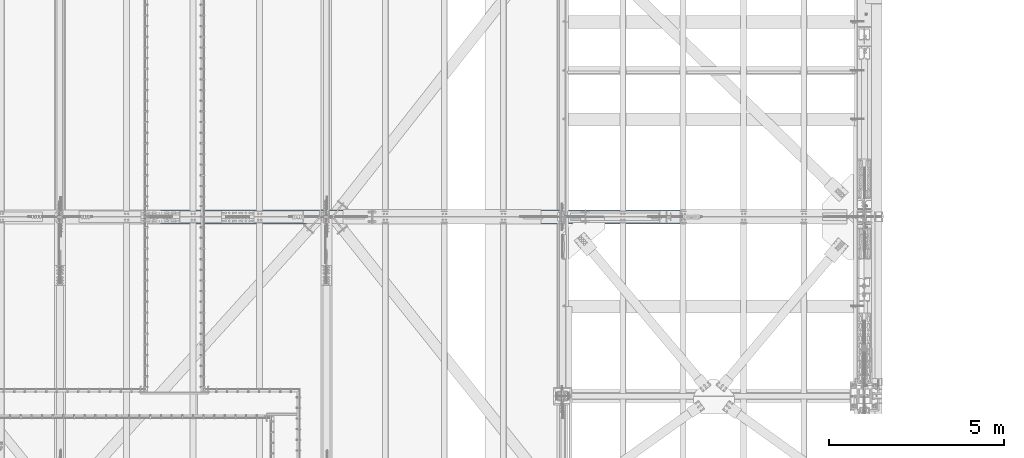
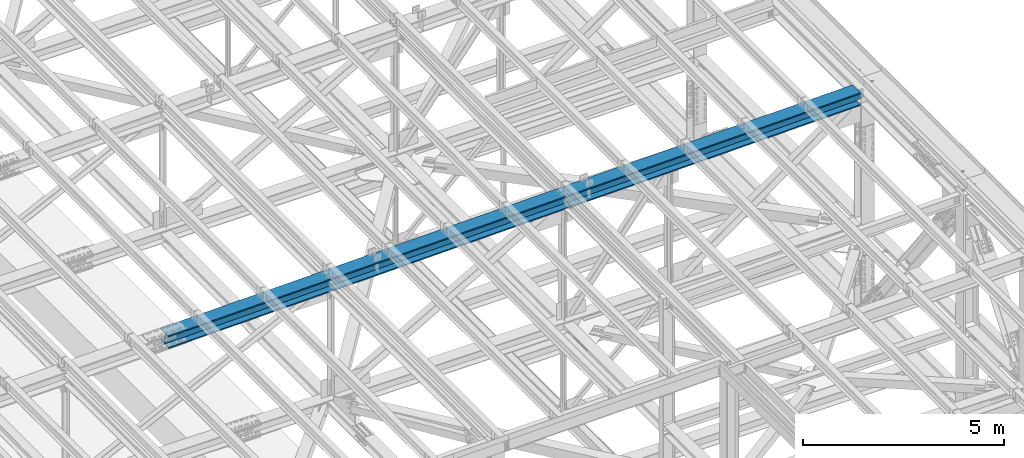
# One storey, part 1834 of 3843: 1 beam, 1 element without a shape of its own.
"""IFC2X3 building model written with IfcOpenShell, lengths in millimetres."""

from ifc_helpers import new_model, si_unit, frame, origin_with_axes, place, context, subcontext, project, spatial, faceted_brep, material, type_object, element, aggregate, save


model = new_model("IFC2X3")

# Units and contexts
model_context = context("Model", 3, precision=1e-05, world=origin_with_axes())
body_context = subcontext(model_context, "Body", "Model", "MODEL_VIEW")
ifc_project = project(units=[si_unit("LENGTHUNIT", "METRE", prefix="MILLI"), si_unit("AREAUNIT", "SQUARE_METRE"), si_unit("VOLUMEUNIT", "CUBIC_METRE"), si_unit("MASSUNIT", "GRAM", prefix="KILO"), si_unit("TIMEUNIT", "SECOND"), si_unit("PLANEANGLEUNIT", "RADIAN"), si_unit("SOLIDANGLEUNIT", "STERADIAN"), si_unit("THERMODYNAMICTEMPERATUREUNIT", "DEGREE_CELSIUS"), si_unit("LUMINOUSINTENSITYUNIT", "LUMEN")], contexts=[model_context])

# Site, building, storey
site_placement = place(None, origin_with_axes())
site = spatial("IfcSite", under=ifc_project, at=site_placement, CompositionType="ELEMENT")
building_placement = place(site_placement, origin_with_axes())
building = spatial("IfcBuilding", under=site, at=building_placement, Name="Undefined", CompositionType="ELEMENT")
storey_placement = place(building_placement, origin_with_axes())
storey = spatial("IfcBuildingStorey", under=building, at=storey_placement, Name="Undefined", CompositionType="ELEMENT", Elevation=0.0)

# Assembly, beam
assembly_placement = place(storey_placement, origin_with_axes())
assembly = element("IfcElementAssembly", 1, at=assembly_placement, inside=storey, Name="BEAM", AssemblyPlace="NOTDEFINED", PredefinedType="RIGID_FRAME")
ifc_material = material(Name="STEEL/A992")
beam_type = type_object("IfcBeamType", Name="W14X193", PredefinedType="NOTDEFINED")
beam_placement = place(assembly_placement, frame((65510.8587019639, 33845.5, 45847.6094284159), z_axis=(-0.0216342480057937, 0.0, 0.999765952267441), x_axis=(0.999765952267441, 0.0, 0.0216342480057898)))
beam = element("IfcBeam", 2, at=beam_placement, type_object=beam_type, material=ifc_material, Name="BEAM", ObjectType="W14X193", context=body_context, shape_type="Brep", body=[
    faceted_brep([(19922.2775877108, -11.1125000000029, -160.337500066009), (19922.2775877108, -200.025000000001, -160.337500066009), (19922.2775877106, -200.025000000001, -196.850000066108), (19922.2775877106, 200.025000000001, -196.850000066108), (19922.2775877108, 200.025000000001, -160.337500066009), (19922.2775877108, 11.1125000000029, -160.337500066009), (19922.2775877108, 11.1125000000029, -152.400001131209), (19922.2775877108, -11.1125000000029, -152.400001131209), (19923.2443176334, 11.1125000000029, -147.539921613119), (19923.2443176334, -11.1125000000029, -147.539921613119), (19925.9973315339, 11.1125000000029, -143.419745144944), (19925.9973315339, -11.1125000000029, -143.419745144944), (19930.1175080021, 11.1125000000029, -140.666731244455), (19930.1175080021, -11.1125000000029, -140.666731244455), (19934.9775875202, 11.1125000000029, -139.700001321871), (19934.9775875202, -11.1125000000029, -139.700001321871), (20111.8448756608, -11.1125000000029, -139.700001322446), (20111.8448756608, 11.1125000000029, -139.700001322446), (6.34999999676074, 11.1125000000029, 160.337500000445), (6.34999999676074, 200.025000000001, 160.337500000445), (19928.627587712, 200.025000000001, 160.337499934882), (19928.627587712, 11.1125000000029, 160.337499934882), (6.34999999676074, -200.025000000001, -196.850000000573), (6.3499999967753, -200.025000000001, -160.337500000467), (6.3499999967753, -11.1125000000029, -160.337500000467), (6.34999999676074, -11.1125000000029, 160.337500000445), (6.34999999676074, -200.025000000001, 160.337500000445), (6.3499999967753, -200.025000000001, 196.850000000544), (6.3499999967753, 200.025000000001, 196.850000000544), (6.3499999967753, 11.1125000000029, -160.337500000467), (6.3499999967753, 200.025000000001, -160.337500000467), (6.34999999676074, 200.025000000001, -196.850000000573), (19928.627587712, -11.1125000000029, 160.337499934882), (19928.627587712, -200.025000000001, 160.337499934882), (19928.6275877121, -200.025000000001, 196.849999934988), (19928.6275877121, 200.025000000001, 196.849999934988), (19928.6275877119, -11.1125000000029, 152.399998490277), (19928.6275877119, 11.1125000000029, 152.399998490277), (19929.5943176345, -11.1125000000029, 147.539918972179), (19929.5943176345, 11.1125000000029, 147.539918972179), (19932.347331535, -11.1125000000029, 143.419742503975), (19932.347331535, 11.1125000000029, 143.419742503975), (19936.4675080032, -11.1125000000029, 140.666728603472), (19936.4675080032, 11.1125000000029, 140.666728603472), (19941.3275875213, -11.1125000000029, 139.699998680859), (19941.3275875213, 11.1125000000029, 139.699998680859), (20117.8908998914, -11.1125000000029, 139.699998680269), (20117.8908998914, 11.1125000000029, 139.699998680269)], [[[0, 1, 2, 3, 4, 5, 6, 7]], [[7, 6, 8, 9]], [[9, 8, 10, 11]], [[11, 10, 12, 13]], [[13, 12, 14, 15]], [[16, 15, 14, 17]], [[18, 19, 20, 21]], [[22, 23, 24, 25, 26, 27, 28, 19, 18, 29, 30, 31]], [[26, 25, 32, 33]], [[27, 26, 33, 34]], [[28, 27, 34, 35]], [[19, 28, 35, 20]], [[34, 33, 32, 36, 37, 21, 20, 35]], [[38, 39, 37, 36]], [[40, 41, 39, 38]], [[42, 43, 41, 40]], [[44, 45, 43, 42]], [[46, 47, 45, 44]], [[47, 46, 16, 17]], [[12, 10, 8, 6, 5, 29, 18, 21, 37, 39, 41, 43, 45, 47, 17, 14]], [[30, 29, 5, 4]], [[31, 30, 4, 3]], [[22, 31, 3, 2]], [[23, 22, 2, 1]], [[24, 23, 1, 0]], [[46, 44, 42, 40, 38, 36, 32, 25, 24, 0, 7, 9, 11, 13, 15, 16]]]),
])
aggregate(assembly, [beam])

save(model, "model.ifc")
